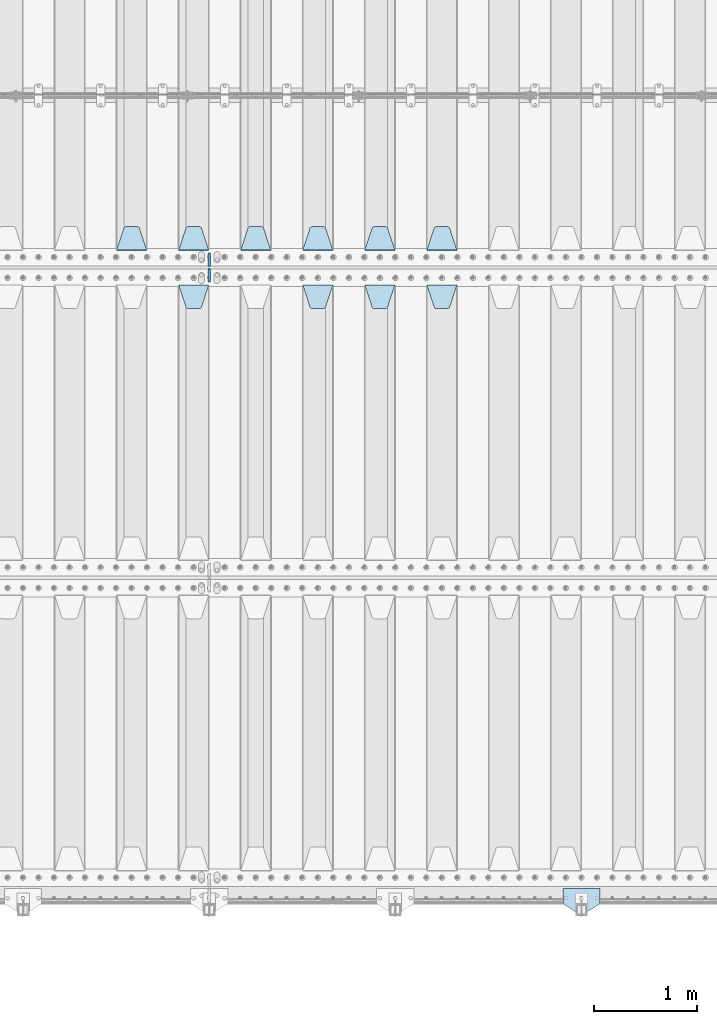
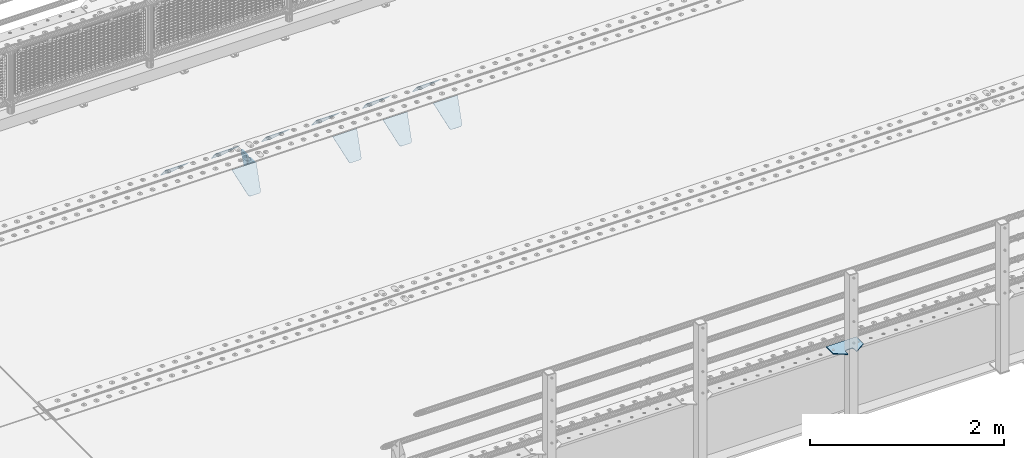
# One storey, part 180 of 219: 13 plates.
"""IFC2X3 building model written with IfcOpenShell, lengths in millimetres."""

from ifc_helpers import new_model, si_unit, frame, origin_with_axes, place, context, subcontext, project, spatial, faceted_brep, material, type_object, element, save


model = new_model("IFC2X3")

# Units and contexts
model_context = context("Model", 3, precision=1e-05, world=origin_with_axes())
body_context = subcontext(model_context, "Body", "Model", "MODEL_VIEW")
ifc_project = project(units=[si_unit("LENGTHUNIT", "METRE", prefix="MILLI"), si_unit("AREAUNIT", "SQUARE_METRE"), si_unit("VOLUMEUNIT", "CUBIC_METRE"), si_unit("MASSUNIT", "GRAM", prefix="KILO"), si_unit("TIMEUNIT", "SECOND"), si_unit("PLANEANGLEUNIT", "RADIAN"), si_unit("SOLIDANGLEUNIT", "STERADIAN"), si_unit("THERMODYNAMICTEMPERATUREUNIT", "DEGREE_CELSIUS"), si_unit("LUMINOUSINTENSITYUNIT", "LUMEN")], contexts=[model_context])

# Site, building, storey
site_placement = place(None, origin_with_axes())
site = spatial("IfcSite", under=ifc_project, at=site_placement, CompositionType="ELEMENT")
building_placement = place(site_placement, origin_with_axes())
building = spatial("IfcBuilding", under=site, at=building_placement, Name="Standard", CompositionType="ELEMENT")
storey_placement = place(building_placement, origin_with_axes())
storey = spatial("IfcBuildingStorey", under=building, at=storey_placement, Name="Undefined", CompositionType="ELEMENT", Elevation=0.0)

# Plates
ifc_material_1 = material(Name="STEEL/S355N")
plate_type_1 = type_object("IfcPlateType", PredefinedType="NOTDEFINED")
plate_1_placement = place(storey_placement, frame((6255.0, 29831.767766956, -1.76776695296758), z_axis=(0.0, -0.707106781186547, -0.707106781186548), x_axis=(1.0, 0.0, 0.0)))
element("IfcPlate", 1, at=plate_1_placement, inside=storey, type_object=plate_type_1, material=ifc_material_1, context=body_context, shape_type="Brep", body=[
    faceted_brep([(0.0, -2.5, 0.0), (69.345504679477, -2.5, 300.171731424834), (69.345504679477, 2.49999999999636, 300.171731424831), (0.0, 2.5, 0.0), (70.9274061199576, -2.50000000000364, 304.8974424154), (70.9274061199576, 2.49999999999636, 304.8974424154), (73.3818627772307, -2.50000000000364, 309.234538108532), (73.3818627772307, 2.49999999999636, 309.234538108532), (76.6187032999569, -2.50000000000364, 313.023683126106), (76.6187032999569, 2.49999999999636, 313.023683126106), (80.5190132704993, -2.50000000000364, 316.125672595372), (80.5190132704993, 2.49999999999636, 316.125672595372), (84.9395038596831, -2.50000000000364, 318.426546230476), (84.9395038596831, 2.5, 318.426546230479), (89.7177759439237, -2.50000000000364, 319.841774983277), (89.7177759439237, 2.5, 319.841774983281), (94.6782862926502, -2.50000000000364, 320.319366455078), (94.6782862926502, 2.49999999999636, 320.319366455078), (195.32171370735, -2.50000000000364, 320.319366455078), (195.32171370735, 2.49999999999636, 320.319366455078), (200.282224056076, -2.50000000000364, 319.841774983277), (200.282224056076, 2.5, 319.841774983281), (205.060496140317, -2.50000000000364, 318.426546230476), (205.060496140317, 2.49999999999636, 318.426546230476), (209.480986729501, -2.50000000000364, 316.125672595372), (209.480986729501, 2.49999999999636, 316.125672595372), (213.381296700043, -2.50000000000364, 313.023683126106), (213.381296700043, 2.49999999999272, 313.023683126106), (216.618137222769, -2.50000000000364, 309.234538108529), (216.618137222769, 2.49999999999636, 309.234538108525), (219.072593880042, -2.50000000000364, 304.8974424154), (219.072593880042, 2.49999999999636, 304.8974424154), (220.654495320523, -2.5, 300.171731424834), (220.654495320523, 2.49999999999636, 300.171731424831), (290.0, -2.50000000000364, 3.63797880709171e-12), (290.0, 2.49999999999636, 0.0)], [[[0, 1, 2, 3]], [[1, 4, 5, 2]], [[4, 6, 7, 5]], [[6, 8, 9, 7]], [[8, 10, 11, 9]], [[10, 12, 13, 11]], [[12, 14, 15, 13]], [[14, 16, 17, 15]], [[16, 18, 19, 17]], [[18, 20, 21, 19]], [[20, 22, 23, 21]], [[22, 24, 25, 23]], [[24, 26, 27, 25]], [[26, 28, 29, 27]], [[28, 30, 31, 29]], [[30, 32, 33, 31]], [[32, 34, 35, 33]], [[34, 0, 3, 35]], [[5, 7, 9, 11, 13, 15, 17, 19, 21, 23, 25, 27, 29, 31, 33, 35, 3, 2]], [[34, 32, 30, 28, 26, 24, 22, 20, 18, 16, 14, 12, 10, 8, 6, 4, 1, 0]]]),
])
plate_2_placement = place(storey_placement, frame((5655.0, 29831.767766956, -1.76776695296758), z_axis=(0.0, -0.707106781186547, -0.707106781186548), x_axis=(1.0, 0.0, 0.0)))
element("IfcPlate", 2, at=plate_2_placement, inside=storey, type_object=plate_type_1, material=ifc_material_1, context=body_context, shape_type="Brep", body=[
    faceted_brep([(0.0, -2.5, 0.0), (69.345504679477, -2.5, 300.171731424834), (69.345504679477, 2.49999999999636, 300.171731424831), (0.0, 2.5, 0.0), (70.9274061199576, -2.50000000000364, 304.8974424154), (70.9274061199576, 2.49999999999636, 304.8974424154), (73.3818627772307, -2.50000000000364, 309.234538108532), (73.3818627772307, 2.49999999999636, 309.234538108532), (76.6187032999569, -2.50000000000364, 313.023683126106), (76.6187032999569, 2.49999999999636, 313.023683126106), (80.5190132704993, -2.50000000000364, 316.125672595372), (80.5190132704993, 2.49999999999636, 316.125672595372), (84.9395038596831, -2.50000000000364, 318.426546230476), (84.9395038596831, 2.5, 318.426546230479), (89.7177759439237, -2.50000000000364, 319.841774983277), (89.7177759439237, 2.5, 319.841774983281), (94.6782862926502, -2.50000000000364, 320.319366455078), (94.6782862926502, 2.49999999999636, 320.319366455078), (195.32171370735, -2.50000000000364, 320.319366455078), (195.32171370735, 2.49999999999636, 320.319366455078), (200.282224056076, -2.50000000000364, 319.841774983277), (200.282224056076, 2.5, 319.841774983281), (205.060496140317, -2.50000000000364, 318.426546230476), (205.060496140317, 2.49999999999636, 318.426546230476), (209.480986729501, -2.50000000000364, 316.125672595372), (209.480986729501, 2.49999999999636, 316.125672595372), (213.381296700043, -2.50000000000364, 313.023683126106), (213.381296700043, 2.49999999999272, 313.023683126106), (216.618137222769, -2.50000000000364, 309.234538108529), (216.618137222769, 2.49999999999636, 309.234538108525), (219.072593880042, -2.50000000000364, 304.8974424154), (219.072593880042, 2.49999999999636, 304.8974424154), (220.654495320523, -2.5, 300.171731424834), (220.654495320523, 2.49999999999636, 300.171731424831), (290.0, -2.50000000000364, 3.63797880709171e-12), (290.0, 2.49999999999636, 0.0)], [[[0, 1, 2, 3]], [[1, 4, 5, 2]], [[4, 6, 7, 5]], [[6, 8, 9, 7]], [[8, 10, 11, 9]], [[10, 12, 13, 11]], [[12, 14, 15, 13]], [[14, 16, 17, 15]], [[16, 18, 19, 17]], [[18, 20, 21, 19]], [[20, 22, 23, 21]], [[22, 24, 25, 23]], [[24, 26, 27, 25]], [[26, 28, 29, 27]], [[28, 30, 31, 29]], [[30, 32, 33, 31]], [[32, 34, 35, 33]], [[34, 0, 3, 35]], [[5, 7, 9, 11, 13, 15, 17, 19, 21, 23, 25, 27, 29, 31, 33, 35, 3, 2]], [[34, 32, 30, 28, 26, 24, 22, 20, 18, 16, 14, 12, 10, 8, 6, 4, 1, 0]]]),
])
plate_3_placement = place(storey_placement, frame((5055.0, 29831.767766956, -1.76776695296758), z_axis=(0.0, -0.707106781186547, -0.707106781186548), x_axis=(1.0, 0.0, 0.0)))
element("IfcPlate", 3, at=plate_3_placement, inside=storey, type_object=plate_type_1, material=ifc_material_1, context=body_context, shape_type="Brep", body=[
    faceted_brep([(0.0, -2.5, 0.0), (69.345504679477, -2.5, 300.171731424834), (69.345504679477, 2.49999999999636, 300.171731424831), (0.0, 2.5, 0.0), (70.9274061199576, -2.50000000000364, 304.8974424154), (70.9274061199576, 2.49999999999636, 304.8974424154), (73.3818627772307, -2.50000000000364, 309.234538108532), (73.3818627772307, 2.49999999999636, 309.234538108532), (76.6187032999569, -2.50000000000364, 313.023683126106), (76.6187032999569, 2.49999999999636, 313.023683126106), (80.5190132704993, -2.50000000000364, 316.125672595372), (80.5190132704993, 2.49999999999636, 316.125672595372), (84.9395038596831, -2.50000000000364, 318.426546230476), (84.9395038596831, 2.5, 318.426546230479), (89.7177759439237, -2.50000000000364, 319.841774983277), (89.7177759439237, 2.5, 319.841774983281), (94.6782862926502, -2.50000000000364, 320.319366455078), (94.6782862926502, 2.49999999999636, 320.319366455078), (195.32171370735, -2.50000000000364, 320.319366455078), (195.32171370735, 2.49999999999636, 320.319366455078), (200.282224056076, -2.50000000000364, 319.841774983277), (200.282224056076, 2.5, 319.841774983281), (205.060496140317, -2.50000000000364, 318.426546230476), (205.060496140317, 2.49999999999636, 318.426546230476), (209.480986729501, -2.50000000000364, 316.125672595372), (209.480986729501, 2.49999999999636, 316.125672595372), (213.381296700043, -2.50000000000364, 313.023683126106), (213.381296700043, 2.49999999999272, 313.023683126106), (216.618137222769, -2.50000000000364, 309.234538108529), (216.618137222769, 2.49999999999636, 309.234538108525), (219.072593880042, -2.50000000000364, 304.8974424154), (219.072593880042, 2.49999999999636, 304.8974424154), (220.654495320523, -2.5, 300.171731424834), (220.654495320523, 2.49999999999636, 300.171731424831), (290.0, -2.50000000000364, 3.63797880709171e-12), (290.0, 2.49999999999636, 0.0)], [[[0, 1, 2, 3]], [[1, 4, 5, 2]], [[4, 6, 7, 5]], [[6, 8, 9, 7]], [[8, 10, 11, 9]], [[10, 12, 13, 11]], [[12, 14, 15, 13]], [[14, 16, 17, 15]], [[16, 18, 19, 17]], [[18, 20, 21, 19]], [[20, 22, 23, 21]], [[22, 24, 25, 23]], [[24, 26, 27, 25]], [[26, 28, 29, 27]], [[28, 30, 31, 29]], [[30, 32, 33, 31]], [[32, 34, 35, 33]], [[34, 0, 3, 35]], [[5, 7, 9, 11, 13, 15, 17, 19, 21, 23, 25, 27, 29, 31, 33, 35, 3, 2]], [[34, 32, 30, 28, 26, 24, 22, 20, 18, 16, 14, 12, 10, 8, 6, 4, 1, 0]]]),
])
plate_4_placement = place(storey_placement, frame((3855.0, 29831.767766956, -1.76776695296758), z_axis=(0.0, -0.707106781186547, -0.707106781186548), x_axis=(1.0, 0.0, 0.0)))
element("IfcPlate", 4, at=plate_4_placement, inside=storey, type_object=plate_type_1, material=ifc_material_1, context=body_context, shape_type="Brep", body=[
    faceted_brep([(0.0, -2.5, 0.0), (69.345504679477, -2.5, 300.171731424834), (69.345504679477, 2.49999999999636, 300.171731424831), (0.0, 2.5, 0.0), (70.9274061199576, -2.50000000000364, 304.8974424154), (70.9274061199576, 2.49999999999636, 304.8974424154), (73.3818627772307, -2.50000000000364, 309.234538108532), (73.3818627772307, 2.49999999999636, 309.234538108532), (76.6187032999569, -2.50000000000364, 313.023683126106), (76.6187032999569, 2.49999999999636, 313.023683126106), (80.5190132704993, -2.50000000000364, 316.125672595372), (80.5190132704993, 2.49999999999636, 316.125672595372), (84.9395038596831, -2.50000000000364, 318.426546230476), (84.9395038596831, 2.5, 318.426546230479), (89.7177759439237, -2.50000000000364, 319.841774983277), (89.7177759439237, 2.5, 319.841774983281), (94.6782862926502, -2.50000000000364, 320.319366455078), (94.6782862926502, 2.49999999999636, 320.319366455078), (195.32171370735, -2.50000000000364, 320.319366455078), (195.32171370735, 2.49999999999636, 320.319366455078), (200.282224056076, -2.50000000000364, 319.841774983277), (200.282224056076, 2.5, 319.841774983281), (205.060496140317, -2.50000000000364, 318.426546230476), (205.060496140317, 2.49999999999636, 318.426546230476), (209.480986729501, -2.50000000000364, 316.125672595372), (209.480986729501, 2.49999999999636, 316.125672595372), (213.381296700043, -2.50000000000364, 313.023683126106), (213.381296700043, 2.49999999999272, 313.023683126106), (216.618137222769, -2.50000000000364, 309.234538108529), (216.618137222769, 2.49999999999636, 309.234538108525), (219.072593880042, -2.50000000000364, 304.8974424154), (219.072593880042, 2.49999999999636, 304.8974424154), (220.654495320523, -2.5, 300.171731424834), (220.654495320523, 2.49999999999636, 300.171731424831), (290.0, -2.50000000000364, 3.63797880709171e-12), (290.0, 2.49999999999636, 0.0)], [[[0, 1, 2, 3]], [[1, 4, 5, 2]], [[4, 6, 7, 5]], [[6, 8, 9, 7]], [[8, 10, 11, 9]], [[10, 12, 13, 11]], [[12, 14, 15, 13]], [[14, 16, 17, 15]], [[16, 18, 19, 17]], [[18, 20, 21, 19]], [[20, 22, 23, 21]], [[22, 24, 25, 23]], [[24, 26, 27, 25]], [[26, 28, 29, 27]], [[28, 30, 31, 29]], [[30, 32, 33, 31]], [[32, 34, 35, 33]], [[34, 0, 3, 35]], [[5, 7, 9, 11, 13, 15, 17, 19, 21, 23, 25, 27, 29, 31, 33, 35, 3, 2]], [[34, 32, 30, 28, 26, 24, 22, 20, 18, 16, 14, 12, 10, 8, 6, 4, 1, 0]]]),
])
plate_5_placement = place(storey_placement, frame((6545.0, 30168.232233047, -1.76776695296758), z_axis=(0.0, 0.707106781186547, -0.707106781186548), x_axis=(-1.0, 0.0, 0.0)))
element("IfcPlate", 5, at=plate_5_placement, inside=storey, type_object=plate_type_1, material=ifc_material_1, context=body_context, shape_type="Brep", body=[
    faceted_brep([(0.0, -2.5, 0.0), (69.345504679477, -2.5, 300.171731424834), (69.345504679477, 2.49999999999636, 300.171731424831), (0.0, 2.5, 0.0), (70.9274061199576, -2.50000000000364, 304.8974424154), (70.9274061199576, 2.49999999999636, 304.8974424154), (73.3818627772307, -2.50000000000364, 309.234538108532), (73.3818627772307, 2.49999999999636, 309.234538108532), (76.6187032999569, -2.50000000000364, 313.023683126106), (76.6187032999569, 2.49999999999636, 313.023683126106), (80.5190132704993, -2.50000000000364, 316.125672595372), (80.5190132704993, 2.49999999999636, 316.125672595372), (84.9395038596831, -2.50000000000364, 318.426546230476), (84.9395038596831, 2.5, 318.426546230479), (89.7177759439237, -2.50000000000364, 319.841774983277), (89.7177759439237, 2.5, 319.841774983281), (94.6782862926502, -2.50000000000364, 320.319366455078), (94.6782862926502, 2.49999999999636, 320.319366455078), (195.32171370735, -2.50000000000364, 320.319366455078), (195.32171370735, 2.49999999999636, 320.319366455078), (200.282224056076, -2.50000000000364, 319.841774983277), (200.282224056076, 2.5, 319.841774983281), (205.060496140317, -2.50000000000364, 318.426546230476), (205.060496140317, 2.49999999999636, 318.426546230476), (209.480986729501, -2.50000000000364, 316.125672595372), (209.480986729501, 2.49999999999636, 316.125672595372), (213.381296700043, -2.50000000000364, 313.023683126106), (213.381296700043, 2.49999999999272, 313.023683126106), (216.618137222769, -2.50000000000364, 309.234538108529), (216.618137222769, 2.49999999999636, 309.234538108525), (219.072593880042, -2.50000000000364, 304.8974424154), (219.072593880042, 2.49999999999636, 304.8974424154), (220.654495320523, -2.5, 300.171731424834), (220.654495320523, 2.49999999999636, 300.171731424831), (290.0, -2.50000000000364, 3.63797880709171e-12), (290.0, 2.49999999999636, 0.0)], [[[0, 1, 2, 3]], [[1, 4, 5, 2]], [[4, 6, 7, 5]], [[6, 8, 9, 7]], [[8, 10, 11, 9]], [[10, 12, 13, 11]], [[12, 14, 15, 13]], [[14, 16, 17, 15]], [[16, 18, 19, 17]], [[18, 20, 21, 19]], [[20, 22, 23, 21]], [[22, 24, 25, 23]], [[24, 26, 27, 25]], [[26, 28, 29, 27]], [[28, 30, 31, 29]], [[30, 32, 33, 31]], [[32, 34, 35, 33]], [[34, 0, 3, 35]], [[5, 7, 9, 11, 13, 15, 17, 19, 21, 23, 25, 27, 29, 31, 33, 35, 3, 2]], [[34, 32, 30, 28, 26, 24, 22, 20, 18, 16, 14, 12, 10, 8, 6, 4, 1, 0]]]),
])
plate_6_placement = place(storey_placement, frame((5945.0, 30168.232233047, -1.76776695296758), z_axis=(0.0, 0.707106781186547, -0.707106781186548), x_axis=(-1.0, 0.0, 0.0)))
element("IfcPlate", 6, at=plate_6_placement, inside=storey, type_object=plate_type_1, material=ifc_material_1, context=body_context, shape_type="Brep", body=[
    faceted_brep([(0.0, -2.5, 0.0), (69.345504679477, -2.5, 300.171731424834), (69.345504679477, 2.49999999999636, 300.171731424831), (0.0, 2.5, 0.0), (70.9274061199576, -2.50000000000364, 304.8974424154), (70.9274061199576, 2.49999999999636, 304.8974424154), (73.3818627772307, -2.50000000000364, 309.234538108532), (73.3818627772307, 2.49999999999636, 309.234538108532), (76.6187032999569, -2.50000000000364, 313.023683126106), (76.6187032999569, 2.49999999999636, 313.023683126106), (80.5190132704993, -2.50000000000364, 316.125672595372), (80.5190132704993, 2.49999999999636, 316.125672595372), (84.9395038596831, -2.50000000000364, 318.426546230476), (84.9395038596831, 2.5, 318.426546230479), (89.7177759439237, -2.50000000000364, 319.841774983277), (89.7177759439237, 2.5, 319.841774983281), (94.6782862926502, -2.50000000000364, 320.319366455078), (94.6782862926502, 2.49999999999636, 320.319366455078), (195.32171370735, -2.50000000000364, 320.319366455078), (195.32171370735, 2.49999999999636, 320.319366455078), (200.282224056076, -2.50000000000364, 319.841774983277), (200.282224056076, 2.5, 319.841774983281), (205.060496140317, -2.50000000000364, 318.426546230476), (205.060496140317, 2.49999999999636, 318.426546230476), (209.480986729501, -2.50000000000364, 316.125672595372), (209.480986729501, 2.49999999999636, 316.125672595372), (213.381296700043, -2.50000000000364, 313.023683126106), (213.381296700043, 2.49999999999272, 313.023683126106), (216.618137222769, -2.50000000000364, 309.234538108529), (216.618137222769, 2.49999999999636, 309.234538108525), (219.072593880042, -2.50000000000364, 304.8974424154), (219.072593880042, 2.49999999999636, 304.8974424154), (220.654495320523, -2.5, 300.171731424834), (220.654495320523, 2.49999999999636, 300.171731424831), (290.0, -2.50000000000364, 3.63797880709171e-12), (290.0, 2.49999999999636, 0.0)], [[[0, 1, 2, 3]], [[1, 4, 5, 2]], [[4, 6, 7, 5]], [[6, 8, 9, 7]], [[8, 10, 11, 9]], [[10, 12, 13, 11]], [[12, 14, 15, 13]], [[14, 16, 17, 15]], [[16, 18, 19, 17]], [[18, 20, 21, 19]], [[20, 22, 23, 21]], [[22, 24, 25, 23]], [[24, 26, 27, 25]], [[26, 28, 29, 27]], [[28, 30, 31, 29]], [[30, 32, 33, 31]], [[32, 34, 35, 33]], [[34, 0, 3, 35]], [[5, 7, 9, 11, 13, 15, 17, 19, 21, 23, 25, 27, 29, 31, 33, 35, 3, 2]], [[34, 32, 30, 28, 26, 24, 22, 20, 18, 16, 14, 12, 10, 8, 6, 4, 1, 0]]]),
])
plate_7_placement = place(storey_placement, frame((5345.0, 30168.232233047, -1.76776695296758), z_axis=(0.0, 0.707106781186547, -0.707106781186548), x_axis=(-1.0, 0.0, 0.0)))
element("IfcPlate", 7, at=plate_7_placement, inside=storey, type_object=plate_type_1, material=ifc_material_1, context=body_context, shape_type="Brep", body=[
    faceted_brep([(0.0, -2.5, 0.0), (69.345504679477, -2.5, 300.171731424834), (69.345504679477, 2.49999999999636, 300.171731424831), (0.0, 2.5, 0.0), (70.9274061199576, -2.50000000000364, 304.8974424154), (70.9274061199576, 2.49999999999636, 304.8974424154), (73.3818627772307, -2.50000000000364, 309.234538108532), (73.3818627772307, 2.49999999999636, 309.234538108532), (76.6187032999569, -2.50000000000364, 313.023683126106), (76.6187032999569, 2.49999999999636, 313.023683126106), (80.5190132704993, -2.50000000000364, 316.125672595372), (80.5190132704993, 2.49999999999636, 316.125672595372), (84.9395038596831, -2.50000000000364, 318.426546230476), (84.9395038596831, 2.5, 318.426546230479), (89.7177759439237, -2.50000000000364, 319.841774983277), (89.7177759439237, 2.5, 319.841774983281), (94.6782862926502, -2.50000000000364, 320.319366455078), (94.6782862926502, 2.49999999999636, 320.319366455078), (195.32171370735, -2.50000000000364, 320.319366455078), (195.32171370735, 2.49999999999636, 320.319366455078), (200.282224056076, -2.50000000000364, 319.841774983277), (200.282224056076, 2.5, 319.841774983281), (205.060496140317, -2.50000000000364, 318.426546230476), (205.060496140317, 2.49999999999636, 318.426546230476), (209.480986729501, -2.50000000000364, 316.125672595372), (209.480986729501, 2.49999999999636, 316.125672595372), (213.381296700043, -2.50000000000364, 313.023683126106), (213.381296700043, 2.49999999999272, 313.023683126106), (216.618137222769, -2.50000000000364, 309.234538108529), (216.618137222769, 2.49999999999636, 309.234538108525), (219.072593880042, -2.50000000000364, 304.8974424154), (219.072593880042, 2.49999999999636, 304.8974424154), (220.654495320523, -2.5, 300.171731424834), (220.654495320523, 2.49999999999636, 300.171731424831), (290.0, -2.50000000000364, 3.63797880709171e-12), (290.0, 2.49999999999636, 0.0)], [[[0, 1, 2, 3]], [[1, 4, 5, 2]], [[4, 6, 7, 5]], [[6, 8, 9, 7]], [[8, 10, 11, 9]], [[10, 12, 13, 11]], [[12, 14, 15, 13]], [[14, 16, 17, 15]], [[16, 18, 19, 17]], [[18, 20, 21, 19]], [[20, 22, 23, 21]], [[22, 24, 25, 23]], [[24, 26, 27, 25]], [[26, 28, 29, 27]], [[28, 30, 31, 29]], [[30, 32, 33, 31]], [[32, 34, 35, 33]], [[34, 0, 3, 35]], [[5, 7, 9, 11, 13, 15, 17, 19, 21, 23, 25, 27, 29, 31, 33, 35, 3, 2]], [[34, 32, 30, 28, 26, 24, 22, 20, 18, 16, 14, 12, 10, 8, 6, 4, 1, 0]]]),
])
plate_8_placement = place(storey_placement, frame((4745.0, 30168.232233047, -1.76776695296758), z_axis=(0.0, 0.707106781186547, -0.707106781186548), x_axis=(-1.0, 0.0, 0.0)))
element("IfcPlate", 8, at=plate_8_placement, inside=storey, type_object=plate_type_1, material=ifc_material_1, context=body_context, shape_type="Brep", body=[
    faceted_brep([(0.0, -2.5, 0.0), (69.345504679477, -2.5, 300.171731424834), (69.345504679477, 2.49999999999636, 300.171731424831), (0.0, 2.5, 0.0), (70.9274061199576, -2.50000000000364, 304.8974424154), (70.9274061199576, 2.49999999999636, 304.8974424154), (73.3818627772307, -2.50000000000364, 309.234538108532), (73.3818627772307, 2.49999999999636, 309.234538108532), (76.6187032999569, -2.50000000000364, 313.023683126106), (76.6187032999569, 2.49999999999636, 313.023683126106), (80.5190132704993, -2.50000000000364, 316.125672595372), (80.5190132704993, 2.49999999999636, 316.125672595372), (84.9395038596831, -2.50000000000364, 318.426546230476), (84.9395038596831, 2.5, 318.426546230479), (89.7177759439237, -2.50000000000364, 319.841774983277), (89.7177759439237, 2.5, 319.841774983281), (94.6782862926502, -2.50000000000364, 320.319366455078), (94.6782862926502, 2.49999999999636, 320.319366455078), (195.32171370735, -2.50000000000364, 320.319366455078), (195.32171370735, 2.49999999999636, 320.319366455078), (200.282224056076, -2.50000000000364, 319.841774983277), (200.282224056076, 2.5, 319.841774983281), (205.060496140317, -2.50000000000364, 318.426546230476), (205.060496140317, 2.49999999999636, 318.426546230476), (209.480986729501, -2.50000000000364, 316.125672595372), (209.480986729501, 2.49999999999636, 316.125672595372), (213.381296700043, -2.50000000000364, 313.023683126106), (213.381296700043, 2.49999999999272, 313.023683126106), (216.618137222769, -2.50000000000364, 309.234538108529), (216.618137222769, 2.49999999999636, 309.234538108525), (219.072593880042, -2.50000000000364, 304.8974424154), (219.072593880042, 2.49999999999636, 304.8974424154), (220.654495320523, -2.5, 300.171731424834), (220.654495320523, 2.49999999999636, 300.171731424831), (290.0, -2.50000000000364, 3.63797880709171e-12), (290.0, 2.49999999999636, 0.0)], [[[0, 1, 2, 3]], [[1, 4, 5, 2]], [[4, 6, 7, 5]], [[6, 8, 9, 7]], [[8, 10, 11, 9]], [[10, 12, 13, 11]], [[12, 14, 15, 13]], [[14, 16, 17, 15]], [[16, 18, 19, 17]], [[18, 20, 21, 19]], [[20, 22, 23, 21]], [[22, 24, 25, 23]], [[24, 26, 27, 25]], [[26, 28, 29, 27]], [[28, 30, 31, 29]], [[30, 32, 33, 31]], [[32, 34, 35, 33]], [[34, 0, 3, 35]], [[5, 7, 9, 11, 13, 15, 17, 19, 21, 23, 25, 27, 29, 31, 33, 35, 3, 2]], [[34, 32, 30, 28, 26, 24, 22, 20, 18, 16, 14, 12, 10, 8, 6, 4, 1, 0]]]),
])
plate_9_placement = place(storey_placement, frame((4145.0, 30168.232233047, -1.76776695296758), z_axis=(0.0, 0.707106781186547, -0.707106781186548), x_axis=(-1.0, 0.0, 0.0)))
element("IfcPlate", 9, at=plate_9_placement, inside=storey, type_object=plate_type_1, material=ifc_material_1, context=body_context, shape_type="Brep", body=[
    faceted_brep([(0.0, -2.5, 0.0), (69.345504679477, -2.5, 300.171731424834), (69.345504679477, 2.49999999999636, 300.171731424831), (0.0, 2.5, 0.0), (70.9274061199576, -2.50000000000364, 304.8974424154), (70.9274061199576, 2.49999999999636, 304.8974424154), (73.3818627772307, -2.50000000000364, 309.234538108532), (73.3818627772307, 2.49999999999636, 309.234538108532), (76.6187032999569, -2.50000000000364, 313.023683126106), (76.6187032999569, 2.49999999999636, 313.023683126106), (80.5190132704993, -2.50000000000364, 316.125672595372), (80.5190132704993, 2.49999999999636, 316.125672595372), (84.9395038596831, -2.50000000000364, 318.426546230476), (84.9395038596831, 2.5, 318.426546230479), (89.7177759439237, -2.50000000000364, 319.841774983277), (89.7177759439237, 2.5, 319.841774983281), (94.6782862926502, -2.50000000000364, 320.319366455078), (94.6782862926502, 2.49999999999636, 320.319366455078), (195.32171370735, -2.50000000000364, 320.319366455078), (195.32171370735, 2.49999999999636, 320.319366455078), (200.282224056076, -2.50000000000364, 319.841774983277), (200.282224056076, 2.5, 319.841774983281), (205.060496140317, -2.50000000000364, 318.426546230476), (205.060496140317, 2.49999999999636, 318.426546230476), (209.480986729501, -2.50000000000364, 316.125672595372), (209.480986729501, 2.49999999999636, 316.125672595372), (213.381296700043, -2.50000000000364, 313.023683126106), (213.381296700043, 2.49999999999272, 313.023683126106), (216.618137222769, -2.50000000000364, 309.234538108529), (216.618137222769, 2.49999999999636, 309.234538108525), (219.072593880042, -2.50000000000364, 304.8974424154), (219.072593880042, 2.49999999999636, 304.8974424154), (220.654495320523, -2.5, 300.171731424834), (220.654495320523, 2.49999999999636, 300.171731424831), (290.0, -2.50000000000364, 3.63797880709171e-12), (290.0, 2.49999999999636, 0.0)], [[[0, 1, 2, 3]], [[1, 4, 5, 2]], [[4, 6, 7, 5]], [[6, 8, 9, 7]], [[8, 10, 11, 9]], [[10, 12, 13, 11]], [[12, 14, 15, 13]], [[14, 16, 17, 15]], [[16, 18, 19, 17]], [[18, 20, 21, 19]], [[20, 22, 23, 21]], [[22, 24, 25, 23]], [[24, 26, 27, 25]], [[26, 28, 29, 27]], [[28, 30, 31, 29]], [[30, 32, 33, 31]], [[32, 34, 35, 33]], [[34, 0, 3, 35]], [[5, 7, 9, 11, 13, 15, 17, 19, 21, 23, 25, 27, 29, 31, 33, 35, 3, 2]], [[34, 32, 30, 28, 26, 24, 22, 20, 18, 16, 14, 12, 10, 8, 6, 4, 1, 0]]]),
])
plate_10_placement = place(storey_placement, frame((3545.0, 30168.232233047, -1.76776695296758), z_axis=(0.0, 0.707106781186547, -0.707106781186548), x_axis=(-1.0, 0.0, 0.0)))
element("IfcPlate", 10, at=plate_10_placement, inside=storey, type_object=plate_type_1, material=ifc_material_1, context=body_context, shape_type="Brep", body=[
    faceted_brep([(0.0, -2.5, 0.0), (69.345504679477, -2.5, 300.171731424834), (69.345504679477, 2.49999999999636, 300.171731424831), (0.0, 2.5, 0.0), (70.9274061199576, -2.50000000000364, 304.8974424154), (70.9274061199576, 2.49999999999636, 304.8974424154), (73.3818627772307, -2.50000000000364, 309.234538108532), (73.3818627772307, 2.49999999999636, 309.234538108532), (76.6187032999569, -2.50000000000364, 313.023683126106), (76.6187032999569, 2.49999999999636, 313.023683126106), (80.5190132704993, -2.50000000000364, 316.125672595372), (80.5190132704993, 2.49999999999636, 316.125672595372), (84.9395038596831, -2.50000000000364, 318.426546230476), (84.9395038596831, 2.5, 318.426546230479), (89.7177759439237, -2.50000000000364, 319.841774983277), (89.7177759439237, 2.5, 319.841774983281), (94.6782862926502, -2.50000000000364, 320.319366455078), (94.6782862926502, 2.49999999999636, 320.319366455078), (195.32171370735, -2.50000000000364, 320.319366455078), (195.32171370735, 2.49999999999636, 320.319366455078), (200.282224056076, -2.50000000000364, 319.841774983277), (200.282224056076, 2.5, 319.841774983281), (205.060496140317, -2.50000000000364, 318.426546230476), (205.060496140317, 2.49999999999636, 318.426546230476), (209.480986729501, -2.50000000000364, 316.125672595372), (209.480986729501, 2.49999999999636, 316.125672595372), (213.381296700043, -2.50000000000364, 313.023683126106), (213.381296700043, 2.49999999999272, 313.023683126106), (216.618137222769, -2.50000000000364, 309.234538108529), (216.618137222769, 2.49999999999636, 309.234538108525), (219.072593880042, -2.50000000000364, 304.8974424154), (219.072593880042, 2.49999999999636, 304.8974424154), (220.654495320523, -2.5, 300.171731424834), (220.654495320523, 2.49999999999636, 300.171731424831), (290.0, -2.50000000000364, 3.63797880709171e-12), (290.0, 2.49999999999636, 0.0)], [[[0, 1, 2, 3]], [[1, 4, 5, 2]], [[4, 6, 7, 5]], [[6, 8, 9, 7]], [[8, 10, 11, 9]], [[10, 12, 13, 11]], [[12, 14, 15, 13]], [[14, 16, 17, 15]], [[16, 18, 19, 17]], [[18, 20, 21, 19]], [[20, 22, 23, 21]], [[22, 24, 25, 23]], [[24, 26, 27, 25]], [[26, 28, 29, 27]], [[28, 30, 31, 29]], [[30, 32, 33, 31]], [[32, 34, 35, 33]], [[34, 0, 3, 35]], [[5, 7, 9, 11, 13, 15, 17, 19, 21, 23, 25, 27, 29, 31, 33, 35, 3, 2]], [[34, 32, 30, 28, 26, 24, 22, 20, 18, 16, 14, 12, 10, 8, 6, 4, 1, 0]]]),
])
plate_type_2 = type_object("IfcPlateType", PredefinedType="NOTDEFINED")
for number, where, z_axis, x_axis in (
    (11, (4150.0, 29860.0, -30.0), (0.0, 0.0, -1.0), (0.0, 1.0, 0.0)),
    (12, (4150.0, 30140.0, -30.0), (0.0, 0.0, -1.0), (0.0, -1.0, 0.0)),
):
    element("IfcPlate", number, at=place(storey_placement, frame(where, z_axis=z_axis, x_axis=x_axis)), inside=storey, type_object=plate_type_2, material=ifc_material_1, context=body_context, shape_type="Brep", body=[
        faceted_brep([(0.0, -10.0, 0.0), (0.0, -10.0, 30.0), (0.0, 10.0, 30.0), (0.0, 10.0, 0.0), (102.0, -10.0, 250.0), (102.0, 10.0, 250.0), (132.0, -10.0, 250.0), (132.0, 10.0, 250.0), (132.0, -10.0, 30.0), (132.0, 10.0, 30.0), (131.544232590368, -10.0, 24.790554669992), (131.544232590368, 10.0, 24.790554669992), (130.190778623579, -10.0, 19.7393957002299), (130.190778623579, 10.0, 19.7393957002299), (127.980762113533, -10.0, 15.0), (127.980762113533, 10.0, 15.0), (124.98133329357, -10.0, 10.7163717094038), (124.98133329357, 10.0, 10.7163717094038), (121.283628290596, -10.0, 7.01866670643062), (121.283628290596, 10.0, 7.01866670643062), (117.0, -10.0, 4.01923788646684), (117.0, 10.0, 4.01923788646684), (112.260604299769, -10.0, 1.80922137642278), (112.260604299769, 10.0, 1.80922137642278), (107.209445330009, -10.0, 0.455767409633722), (107.209445330009, 10.0, 0.455767409633722), (102.0, -10.0, 0.0), (102.0, 10.0, 0.0)], [[[0, 1, 2, 3]], [[1, 4, 5, 2]], [[4, 6, 7, 5]], [[6, 8, 9, 7]], [[8, 10, 11, 9]], [[10, 12, 13, 11]], [[12, 14, 15, 13]], [[14, 16, 17, 15]], [[16, 18, 19, 17]], [[18, 20, 21, 19]], [[20, 22, 23, 21]], [[22, 24, 25, 23]], [[24, 26, 27, 25]], [[26, 0, 3, 27]], [[5, 7, 9, 11, 13, 15, 17, 19, 21, 23, 25, 27, 3, 2]], [[26, 24, 22, 20, 18, 16, 14, 12, 10, 8, 6, 4, 1, 0]]]),
    ])
ifc_material_2 = material(Name="STEEL/S355J2")
plate_type_3 = type_object("IfcPlateType", PredefinedType="NOTDEFINED")
plate_11_placement = place(storey_placement, frame((7930.0, 23995.0, 5.00000000004911), z_axis=(0.0, -1.0, 0.0), x_axis=(-1.0, 0.0, 0.0)))
element("IfcPlate", 13, at=plate_11_placement, inside=storey, type_object=plate_type_3, material=ifc_material_2, context=body_context, shape_type="Brep", body=[
    faceted_brep([(0.0, -5.0, 0.0), (2.31396552408114e-06, -5.0, 145.0), (2.31396552408114e-06, 5.0, 145.0), (0.0, 5.0, 0.0), (130.0, -5.0, 230.0), (130.0, 5.0, 230.0), (130.0, -5.0, 180.0), (130.0, 5.0, 180.0), (130.48036798992, -5.0, 175.122741949599), (130.48036798992, 5.0, 175.122741949599), (131.903011687218, -5.0, 170.432914190875), (131.903011687218, 5.0, 170.432914190875), (134.213259692437, -5.0, 166.110744174512), (134.213259692437, 5.0, 166.110744174512), (137.322330470337, -5.0, 162.322330470335), (137.322330470337, 5.0, 162.322330470335), (141.11074417451, -5.0, 159.213259692435), (141.11074417451, 5.0, 159.213259692435), (145.432914190873, -5.0, 156.903011687216), (145.432914190873, 5.0, 156.903011687216), (150.122741949597, -5.0, 155.48036798992), (150.122741949597, 5.0, 155.48036798992), (155.0, -5.0, 155.0), (155.0, 5.0, 155.0), (205.0, -5.0, 155.0), (205.0, 5.0, 155.0), (209.877258050403, -5.0, 155.48036798992), (209.877258050403, 5.0, 155.48036798992), (214.567085809127, -5.0, 156.903011687216), (214.567085809127, 5.0, 156.903011687216), (218.88925582549, -5.0, 159.213259692435), (218.88925582549, 5.0, 159.213259692435), (222.677669529663, -5.0, 162.322330470335), (222.677669529663, 5.0, 162.322330470335), (225.786740307563, -5.0, 166.110744174512), (225.786740307563, 5.0, 166.110744174512), (228.096988312782, -5.0, 170.432914190875), (228.096988312782, 5.0, 170.432914190875), (229.51963201008, -5.0, 175.122741949599), (229.51963201008, 5.0, 175.122741949599), (230.0, -5.0, 180.0), (230.0, 5.0, 180.0), (230.0, -5.0, 230.0), (230.0, 5.0, 230.0), (360.0, -5.0, 145.0), (360.0, 5.0, 145.0), (360.0, -5.0, -7.27595761418343e-12), (360.0, 5.0, -7.27595761418343e-12)], [[[0, 1, 2, 3]], [[1, 4, 5, 2]], [[4, 6, 7, 5]], [[6, 8, 9, 7]], [[8, 10, 11, 9]], [[10, 12, 13, 11]], [[12, 14, 15, 13]], [[14, 16, 17, 15]], [[16, 18, 19, 17]], [[18, 20, 21, 19]], [[20, 22, 23, 21]], [[22, 24, 25, 23]], [[24, 26, 27, 25]], [[26, 28, 29, 27]], [[28, 30, 31, 29]], [[30, 32, 33, 31]], [[32, 34, 35, 33]], [[34, 36, 37, 35]], [[36, 38, 39, 37]], [[38, 40, 41, 39]], [[40, 42, 43, 41]], [[42, 44, 45, 43]], [[44, 46, 47, 45]], [[46, 0, 3, 47]], [[5, 7, 9, 11, 13, 15, 17, 19, 21, 23, 25, 27, 29, 31, 33, 35, 37, 39, 41, 43, 45, 47, 3, 2]], [[46, 44, 42, 40, 38, 36, 34, 32, 30, 28, 26, 24, 22, 20, 18, 16, 14, 12, 10, 8, 6, 4, 1, 0]]]),
])

save(model, "model.ifc")
